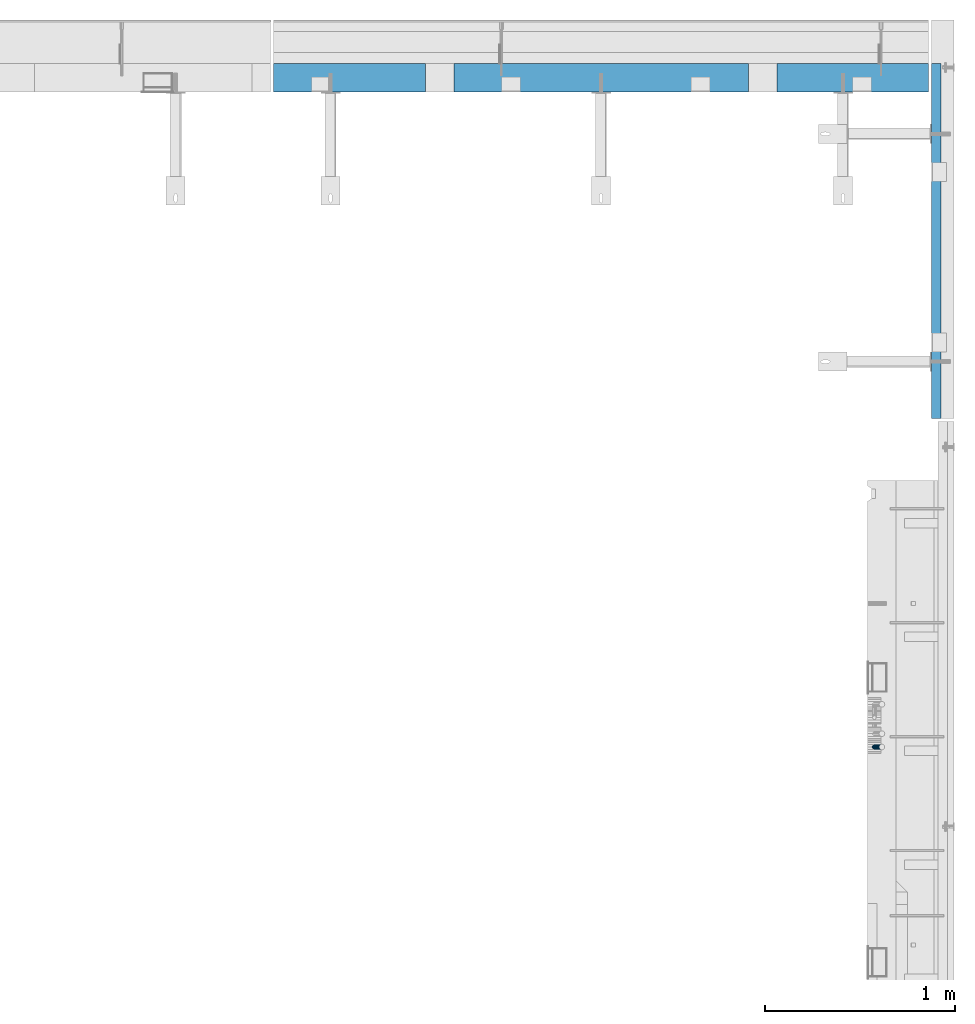
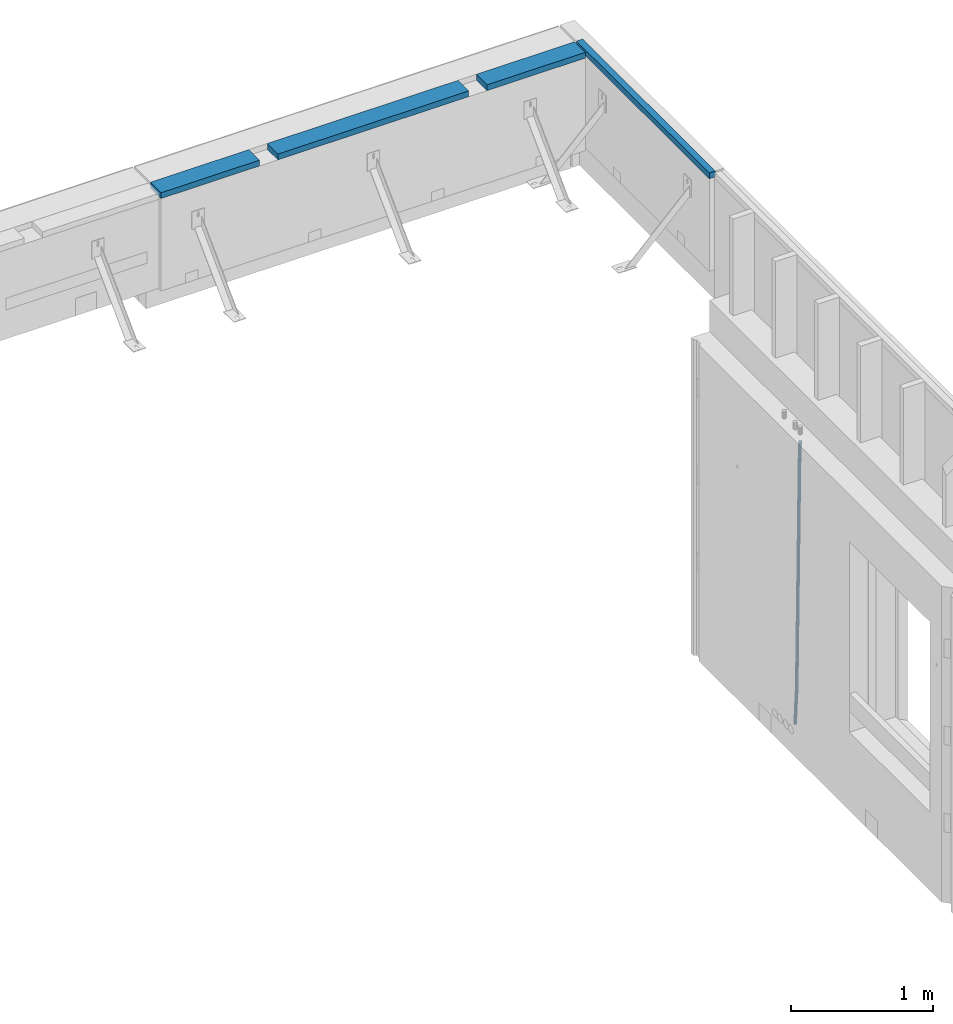
# One storey, part 45 of 153: 3 beams, 3 elements without a shape of their own.
"""IFC2X3 building model written with IfcOpenShell, lengths in millimetres."""

from ifc_helpers import new_model, si_unit, frame, origin_with_axes, place, context, subcontext, project, spatial, faceted_brep, material, type_object, element, aggregate, save


model = new_model("IFC2X3")

# Units and contexts
model_context = context("Model", 3, precision=1e-05, world=origin_with_axes())
body_context = subcontext(model_context, "Body", "Model", "MODEL_VIEW")
ifc_project = project(units=[si_unit("LENGTHUNIT", "METRE", prefix="MILLI"), si_unit("AREAUNIT", "SQUARE_METRE"), si_unit("VOLUMEUNIT", "CUBIC_METRE"), si_unit("MASSUNIT", "GRAM", prefix="KILO"), si_unit("TIMEUNIT", "SECOND"), si_unit("PLANEANGLEUNIT", "RADIAN"), si_unit("SOLIDANGLEUNIT", "STERADIAN"), si_unit("THERMODYNAMICTEMPERATUREUNIT", "DEGREE_CELSIUS"), si_unit("LUMINOUSINTENSITYUNIT", "LUMEN")], contexts=[model_context])

# Site, building, storey
site_placement = place(None, origin_with_axes())
site = spatial("IfcSite", under=ifc_project, at=site_placement, CompositionType="ELEMENT")
building_placement = place(site_placement, origin_with_axes())
building = spatial("IfcBuilding", under=site, at=building_placement, CompositionType="ELEMENT")
storey_placement = place(building_placement, origin_with_axes())
storey = spatial("IfcBuildingStorey", under=building, at=storey_placement, Name="8", CompositionType="ELEMENT", Elevation=0.0)

# Assembly, beam
assembly_1_placement = place(storey_placement, origin_with_axes())
assembly_1 = element("IfcElementAssembly", 1, at=assembly_1_placement, inside=storey, AssemblyPlace="NOTDEFINED", PredefinedType="REINFORCEMENT_UNIT")
ifc_material_1 = material(Name="TIMBER")
beam_type_1 = type_object("IfcBeamType", PredefinedType="NOTDEFINED")
beam_1_placement = place(assembly_1_placement, frame((31779.9999728033, 22695.0, 103545.0), z_axis=(0.0, 0.0, 1.0), x_axis=(1.0, 0.0, 0.0)))
beam_1 = element("IfcBeam", 2, at=beam_1_placement, type_object=beam_type_1, material=ifc_material_1, context=body_context, shape_type="Brep", body=[
    faceted_brep([(0.0, -75.0, -25.0), (1.81898940354586e-12, -75.0000000000009, 25.0), (1.81898940354586e-12, 75.0, 25.0), (0.0, 75.0, -25.0), (800.999675264662, -75.0, -25.0), (800.999675264662, -75.0, 25.0), (800.999696264662, 74.9995409673429, 25.0), (800.999696264662, 75.0, -25.0), (2650.99969626429, 74.9988790673451, 25.0), (2650.99969626429, 75.0000000000036, -25.0), (2650.99967526454, -75.0, -25.0), (2650.99967526454, -75.0, 25.0), (3449.9963989386, -75.0, 25.0), (3449.9963989386, -75.0, -25.0), (3449.99639893861, 75.0000000000036, -25.0), (3449.99639893861, 75.0000000000036, 25.0), (2500.99969626454, 74.9989000673449, 25.0), (2500.99967526454, -75.0000000000036, 25.0), (2500.99967526454, -75.0000000000036, -25.0), (2500.99969626454, 75.0000000000036, -25.0), (950.999696264415, 74.9995199673467, 25.0), (950.999696264415, 75.0000000000036, -25.0), (950.999675264662, -75.0, -25.0), (950.999675264662, -75.0, 25.0)], [[[0, 1, 2, 3]], [[1, 0, 4, 5]], [[2, 1, 5, 6]], [[3, 2, 6, 7]], [[0, 3, 7, 4]], [[6, 5, 4, 7]], [[8, 9, 10, 11]], [[12, 13, 14, 15]], [[12, 15, 8, 11]], [[13, 12, 11, 10]], [[14, 13, 10, 9]], [[15, 14, 9, 8]], [[16, 17, 18, 19]], [[20, 21, 22, 23]], [[21, 20, 16, 19]], [[22, 21, 19, 18]], [[23, 22, 18, 17]], [[20, 23, 17, 16]]]),
])
aggregate(assembly_1, [beam_1])

assembly_2_placement = place(storey_placement, origin_with_axes())
assembly_2 = element("IfcElementAssembly", 3, at=assembly_2_placement, inside=storey, AssemblyPlace="NOTDEFINED", PredefinedType="REINFORCEMENT_UNIT")
ifc_material_2 = material()
beam_type_2 = type_object("IfcBeamType", Name="D25", PredefinedType="NOTDEFINED")
beam_2_placement = place(assembly_2_placement, frame((34944.9999977209, 19170.0002441367, 99990.0), z_axis=(0.999642804629538, 0.000205762999925497, -0.0267249099901003), x_axis=(0.0267249109941254, -4.30000210532798e-08, 0.999642825779465)))
beam_2 = element("IfcBeam", 4, at=beam_2_placement, type_object=beam_type_2, material=ifc_material_2, Name="JM25", ObjectType="D25", context=body_context, shape_type="Brep", body=[
    faceted_brep([(-7.41420080885291e-08, -12.5, -3.63797880709171e-12), (-6.42030499875546e-08, -10.8253175473074, -6.25000000000364), (60.4103898235917, -10.8253175318459, -6.2499999938409), (60.4103898269532, -12.4999999845422, 6.16273609921336e-09), (-3.70782800018787e-08, -6.25000000000364, -10.8253175473074), (60.4103898202884, -6.24999998454587, -10.8253175411446), (-1.45519152283669e-11, -3.63797880709171e-12, -12.5), (60.4103898179019, 1.54577719513327e-08, -12.4999999938373), (3.70637280866504e-08, 6.25, -10.8253175473074), (60.410389817087, 6.25000001545777, -10.825317541141), (6.42030499875546e-08, 10.8253175473001, -6.25000000000364), (60.410389818062, 10.8253175627578, -6.24999999383726), (7.41420080885291e-08, 12.4999999999927, 0.0), (60.4103898205503, 12.5000000154541, 6.16273609921336e-09), (6.42176019027829e-08, 10.8253175473001, 6.24999999999636), (60.4103898238973, 10.8253175627651, 6.2500000061591), (3.70928319171071e-08, 6.24999999999636, 10.8253175473037), (60.4103898272151, 6.25000001546141, 10.8253175534664), (1.45519152283669e-11, -3.63797880709171e-12, 12.4999999999964), (60.4103898296162, 1.54541339725256e-08, 12.5000000061591), (-3.7049176171422e-08, -6.25000000000364, 10.8253175473001), (60.4103898304165, -6.24999998454587, 10.8253175534701), (-6.41884980723262e-08, -10.8253175473074, 6.25), (60.4103898294561, -10.8253175318459, 6.25000000616637), (61.0324985728803, -10.8253175316895, -6.24999999377542), (60.991802792938, -12.4999999843931, 6.22458173893392e-09), (61.0622854283865, -6.24999998437852, -10.8253175410755), (61.0731819955545, 1.5628756955266e-08, -12.4999999937718), (61.0622685480339, 6.25000001562512, -10.8253175410791), (61.032469335245, 10.8253175629216, -6.24999999377178), (60.9917690322181, 12.5000000156033, 6.22458173893392e-09), (60.9510732522613, 10.8253175629034, 6.25000000621731), (60.9212863967696, 6.25000001558874, 10.8253175535247), (60.9103898296162, 1.55814632307738e-08, 12.5000000062137), (60.9213032771368, -6.24999998441126, 10.8253175535174), (60.9511024898966, -10.8253175317113, 6.25000000621731), (61.6545545670233, -10.8253158516927, -6.24189838219536), (61.573166454793, -12.499998414296, 0.00757164385504439), (61.7141257553885, -6.24999822394238, -10.8168280205282), (61.7359179680789, 1.80548886419274e-06, -12.491368569139), (61.7140919992817, 6.25000177601396, -10.8168282403167), (61.6544960997562, 10.8253192428383, -6.2418987628771), (61.5730989426083, 12.5000015856094, 0.0075712042817031), (61.4917108303925, 10.8253190230062, 6.25704123032847), (61.4321396420273, 6.25000139525582, 10.8319708686649), (61.4103474293224, 1.36582457344048e-06, 12.5065114172721), (61.4321733981196, -6.24999860470052, 10.8319710884571), (61.4917692976451, -10.8253160715249, 6.25704161101385), (176.524302641745, -10.8250056210964, -4.74584321979273), (176.442914529529, -12.4996881836996, 1.50362680625403), (176.583873830095, -6.24968799334965, -9.3207728581292), (176.605666042786, 0.000312036081595579, -10.9953134067364), (176.583840074018, 6.25031200660669, -9.32077307791769), (176.524244174492, 10.8256294734347, -4.74584360047811), (176.44284701733, 12.5003118162058, 1.50362636668069), (176.361458905099, 10.8256292535989, 7.75309639272746), (176.301887716749, 6.25031162585219, 12.3280260310676), (176.280095504058, 0.000311596420942806, 14.0025665796711), (176.301921472827, -6.24968837410415, 12.3280262508561), (176.361517372367, -10.8250058409321, 7.75309677341284), (177.085397012124, -10.8250041057399, -4.73853556792164), (176.983633547483, -12.4996867233749, 1.51066909103247), (177.159881729676, -6.24968643771717, -9.31327097355097), (177.187129580227, 0.000313606451527448, -10.987740468332), (177.159839524218, 6.25031356221734, -9.31327130338468), (177.085323910098, 10.8256309887511, -4.73853613920801), (176.983549136537, 12.5003132764905, 1.51066843136869), (176.881785671867, 10.8256306588555, 7.7598730903228), (176.80730095433, 6.25031299082912, 12.3346084959521), (176.780053103794, 0.000312946667690994, 14.0090779907332), (176.807343159802, -6.2496870091054, 12.3346088257895), (176.881858773908, -10.8250044356355, 7.7598736616128), (177.646431799818, -10.8250018318176, -4.72756919822132), (177.524295146417, -12.4996845320202, 1.52123723245313), (177.735828462886, -6.24968410334986, -9.30201312475765), (177.768531371941, 0.00031596292683389, -10.9763759912421), (177.735777808921, 6.25031589654827, -9.30201361973741), (177.646344064575, 10.8256332626152, -4.72757005553649), (177.524193838486, 12.5003154677688, 1.52123624250817), (177.402057185071, 10.8256327675663, 7.77004267317898), (177.312660521988, 6.2503150390985, 12.3444865997226), (177.279957612933, 0.00031497282179771, 14.0188494661961), (177.312711175953, -6.24968496079964, 12.3444870946951), (177.402144920314, -10.8250023268702, 7.77004353049415), (299.377443161706, -10.8245084454466, -2.34813158632096), (299.255306508276, -12.4991911456491, 3.90067484435349), (299.466839824803, -6.24919071697514, -6.92257551286093), (299.499542733873, 0.0008093492979242, -8.59693837933446), (299.466789170867, 6.250809282923, -6.92257600783341), (299.377355426492, 10.8261266489935, -2.34813244364341), (299.255205200388, 12.5008088541435, 3.90067385440125), (299.133068546944, 10.826126153941, 10.1494802850757), (299.043671883861, 6.25080842546959, 14.7239242116229), (299.010968974762, 0.000808359200163977, 16.3982870780892), (299.043722537797, -6.24919157442127, 14.7239247065918), (299.133156282158, -10.8245089404954, 10.1494811423981), (299.98561436501, -10.8245059804758, -2.33624385599614), (299.97179243555, -12.4991882411778, 3.91467976726199), (299.995742293278, -6.24918857328521, -6.91223722345239), (299.999447243041, 0.000811375455668895, -8.58716690387519), (299.995736475976, 6.25081142679483, -6.91223684201032), (299.985604289133, 10.8261291142808, -2.33624319533556), (299.971750386685, 12.5008117588586, 3.91467993563856), (299.957928457196, 10.8261294971744, 10.1656035610831), (299.947800528913, 6.25081208998381, 14.7415969285394), (299.944095579151, 0.00081214124293183, 16.4165266089549), (299.947806346216, -6.24918791008895, 14.7415965471009), (299.957938533058, -10.8245055975785, 10.1656029004225), (300.593832239858, -10.8245078794353, -2.34543881707941), (300.688302931099, -12.4991904788549, 3.90384712594823), (300.524685350189, -6.24919022474205, -6.92023371784308), (300.499390115292, 0.000809814544481924, -8.59472497713432), (300.524724372954, 6.25080977519247, -6.92023401429469), (300.593899829313, 10.8261272150703, -2.34543933054374), (300.688380976673, 12.5008095210287, 3.90384653304136), (300.782851667915, 10.8261269216127, 10.1531324760799), (300.851998557599, 6.25080926691589, 14.7279273768363), (300.877293792495, 0.000809227632998955, 16.4024186361276), (300.851959534804, -6.24919073302226, 14.7279276732806), (300.782784078474, -10.8245081728965, 10.153132989537), (2293.32930409742, -10.8307295605009, -32.4713622331001), (2293.42377478865, -12.5054121599169, -26.2220762900724), (2293.26015720774, -6.2554119058077, -37.0461571338565), (2293.23486197284, -0.00541186651753378, -38.7206483931477), (2293.26019623051, 6.24458809413409, -37.0461574303008), (2293.32937168686, 10.8199055340046, -32.4713627465644), (2293.42385283421, 12.4945878399631, -26.2220768829684), (2293.51832352545, 10.8199052405434, -19.972790939948), (2293.58747041514, 6.24458758585388, -15.3979960391844), (2293.61276565003, -0.00541245343265473, -13.7235047798931), (2293.58743139236, -6.25541241408428, -15.3979957427327), (2293.51825593603, -10.8307298539585, -19.9727904264691), (2294.0420846676, -10.8307317859326, -32.4821379598216), (2294.03681932652, -12.5054140739521, -26.2313442200393), (2294.06778164886, -6.2554144273563, -37.0583666982457), (2294.10702478497, -0.00541458957013674, -38.7338336404937), (2294.14929890928, 6.24458531819619, -37.0595987724118), (2294.18327670435, 10.8199028679592, -32.4842719748667), (2294.1998538474, 12.4945854171456, -26.2338083683717), (2294.19458850632, 10.819903129126, -19.9830146285858), (2294.16889152506, 6.24458577054975, -15.4067858901581), (2294.12964838895, -0.0054140672327776, -13.7313189479173), (2294.08737426462, -6.2554139749991, -15.4055538159919), (2294.05339646956, -10.8307315247621, -19.9808806135297), (2294.75482297382, -10.84002603931, -32.4726521173216), (2294.64982751427, -12.513407826169, -26.2231856868602), (2294.87535820232, -6.26594539088183, -37.0476186524102), (2294.97913588268, -0.0167870967634371, -38.7222267036377), (2295.0383488692, 6.23299192477134, -37.0477663960555), (2295.03713108998, 10.8087684320271, -32.4729080168181), (2294.97580884799, 12.4844668051373, -26.2234811741473), (2294.87081338844, 10.8110850182784, -19.9740147436787), (2294.7502781599, 6.23700436985018, -15.3990482086047), (2294.64650047956, -0.0121539242718427, -13.7244401573698), (2294.58728749304, -6.26193294580662, -15.3989004649666), (2294.58850527227, -10.8377094530588, -19.9737588441894), (2316.44667268227, -11.1228921988077, -32.1839550346631), (2316.34167722271, -12.7962739856739, -25.9344886042054), (2316.56720791078, -6.54881155039038, -36.7589215697517), (2316.67098559113, -0.299653256264719, -38.4335296209792), (2316.73019857766, 5.95012576527006, -36.759069313397), (2316.72898079845, 10.5259022725259, -32.1842109341669), (2316.66765855643, 12.2016006456361, -25.9347840914961), (2316.56266309689, 10.5282188587698, -19.6853176610275), (2316.44212786836, 5.95413821035254, -15.1103511259389), (2316.33835018802, -0.295020083769487, -13.4357430747186), (2316.27913720149, -6.54479910530426, -15.1102033823008), (2316.28035498071, -11.1205756125637, -19.685061761531), (2317.13234804722, -11.1318335458927, -32.1748293731798), (2317.04181141085, -12.8054038787741, -25.9251705100723), (2317.2154741603, -6.5572650749491, -36.7502937866229), (2317.26891617525, -0.307450393454928, -38.4255717558117), (2317.27835434731, 5.94297770185585, -36.7517739018112), (2317.24125972588, 10.5192220504723, -32.1773930078925), (2317.16757178486, 12.1950816748285, -25.9281307404563), (2317.0770351485, 10.5215113419545, -19.6784718773561), (2316.99390903539, 5.94694287101083, -15.1030074639057), (2316.94046702047, -0.302871810494253, -13.4277294947169), (2316.9310288484, -6.55329990579412, -15.1015273487101), (2316.96812346982, -11.1295442544142, -19.6759082426288), (2317.81808136747, -11.1298054502913, -32.1659056455355), (2317.74200467508, -12.803315894289, -25.9160547315114), (2317.86379538118, -6.55536082026447, -36.7418676070083), (2317.8668976831, -0.305700748642266, -38.417815303761), (2317.82655701396, 5.94458339541234, -36.7446799039099), (2317.75358262347, 10.5207330230332, -32.1707766866384), (2317.66752794063, 12.1965725370646, -25.9216793252963), (2317.59145124823, 10.5230620930706, -19.6718284112721), (2317.54573723453, 5.94861746304377, -15.0958664497994), (2317.54263493262, -0.301042608574789, -13.4199187530394), (2317.58297560175, -6.55132675263303, -15.0930541529051), (2317.65594999224, -11.1274763802539, -19.6669573701693), (2417.81884292323, -10.831603083323, -30.8687911350135), (2417.74276623082, -12.505113527317, -24.618940220982), (2417.86455693691, -6.25715845329614, -35.4447530964935), (2417.86765923884, -0.00749838167394046, -37.1207007932499), (2417.82731856969, 6.24278576237703, -35.4475653933878), (2417.75434417921, 10.8189353900088, -30.8736621761236), (2417.66828949639, 12.494774904033, -24.6245648147851), (2417.59221280397, 10.8212644600353, -18.3747139007501), (2417.54649879028, 6.2468198300121, -13.79875193927), (2417.54339648837, -0.00284024161010166, -12.1228042425173), (2417.5837371575, -6.25312438566107, -13.795939642383), (2417.65671154798, -10.8292740132893, -18.3698428596399)], [[[0, 1, 2, 3]], [[1, 4, 5, 2]], [[4, 6, 7, 5]], [[6, 8, 9, 7]], [[8, 10, 11, 9]], [[10, 12, 13, 11]], [[12, 14, 15, 13]], [[14, 16, 17, 15]], [[16, 18, 19, 17]], [[18, 20, 21, 19]], [[20, 22, 23, 21]], [[22, 0, 3, 23]], [[22, 20, 18, 16, 14, 12, 10, 8, 6, 4, 1, 0]], [[3, 2, 24, 25]], [[2, 5, 26, 24]], [[5, 7, 27, 26]], [[7, 9, 28, 27]], [[9, 11, 29, 28]], [[11, 13, 30, 29]], [[13, 15, 31, 30]], [[15, 17, 32, 31]], [[17, 19, 33, 32]], [[19, 21, 34, 33]], [[21, 23, 35, 34]], [[23, 3, 25, 35]], [[25, 24, 36, 37]], [[24, 26, 38, 36]], [[26, 27, 39, 38]], [[27, 28, 40, 39]], [[28, 29, 41, 40]], [[29, 30, 42, 41]], [[30, 31, 43, 42]], [[31, 32, 44, 43]], [[32, 33, 45, 44]], [[33, 34, 46, 45]], [[34, 35, 47, 46]], [[35, 25, 37, 47]], [[37, 36, 48, 49]], [[36, 38, 50, 48]], [[38, 39, 51, 50]], [[39, 40, 52, 51]], [[40, 41, 53, 52]], [[41, 42, 54, 53]], [[42, 43, 55, 54]], [[43, 44, 56, 55]], [[44, 45, 57, 56]], [[45, 46, 58, 57]], [[46, 47, 59, 58]], [[47, 37, 49, 59]], [[49, 48, 60, 61]], [[48, 50, 62, 60]], [[50, 51, 63, 62]], [[51, 52, 64, 63]], [[52, 53, 65, 64]], [[53, 54, 66, 65]], [[54, 55, 67, 66]], [[55, 56, 68, 67]], [[56, 57, 69, 68]], [[57, 58, 70, 69]], [[58, 59, 71, 70]], [[59, 49, 61, 71]], [[61, 60, 72, 73]], [[60, 62, 74, 72]], [[62, 63, 75, 74]], [[63, 64, 76, 75]], [[64, 65, 77, 76]], [[65, 66, 78, 77]], [[66, 67, 79, 78]], [[67, 68, 80, 79]], [[68, 69, 81, 80]], [[69, 70, 82, 81]], [[70, 71, 83, 82]], [[71, 61, 73, 83]], [[73, 72, 84, 85]], [[72, 74, 86, 84]], [[74, 75, 87, 86]], [[75, 76, 88, 87]], [[76, 77, 89, 88]], [[77, 78, 90, 89]], [[78, 79, 91, 90]], [[79, 80, 92, 91]], [[80, 81, 93, 92]], [[81, 82, 94, 93]], [[82, 83, 95, 94]], [[83, 73, 85, 95]], [[85, 84, 96, 97]], [[84, 86, 98, 96]], [[86, 87, 99, 98]], [[87, 88, 100, 99]], [[88, 89, 101, 100]], [[89, 90, 102, 101]], [[90, 91, 103, 102]], [[91, 92, 104, 103]], [[92, 93, 105, 104]], [[93, 94, 106, 105]], [[94, 95, 107, 106]], [[95, 85, 97, 107]], [[97, 96, 108, 109]], [[96, 98, 110, 108]], [[98, 99, 111, 110]], [[99, 100, 112, 111]], [[100, 101, 113, 112]], [[101, 102, 114, 113]], [[102, 103, 115, 114]], [[103, 104, 116, 115]], [[104, 105, 117, 116]], [[105, 106, 118, 117]], [[106, 107, 119, 118]], [[107, 97, 109, 119]], [[109, 108, 120, 121]], [[108, 110, 122, 120]], [[110, 111, 123, 122]], [[111, 112, 124, 123]], [[112, 113, 125, 124]], [[113, 114, 126, 125]], [[114, 115, 127, 126]], [[115, 116, 128, 127]], [[116, 117, 129, 128]], [[117, 118, 130, 129]], [[118, 119, 131, 130]], [[119, 109, 121, 131]], [[121, 120, 132, 133]], [[120, 122, 134, 132]], [[122, 123, 135, 134]], [[123, 124, 136, 135]], [[124, 125, 137, 136]], [[125, 126, 138, 137]], [[126, 127, 139, 138]], [[127, 128, 140, 139]], [[128, 129, 141, 140]], [[129, 130, 142, 141]], [[130, 131, 143, 142]], [[131, 121, 133, 143]], [[133, 132, 144, 145]], [[132, 134, 146, 144]], [[134, 135, 147, 146]], [[135, 136, 148, 147]], [[136, 137, 149, 148]], [[137, 138, 150, 149]], [[138, 139, 151, 150]], [[139, 140, 152, 151]], [[140, 141, 153, 152]], [[141, 142, 154, 153]], [[142, 143, 155, 154]], [[143, 133, 145, 155]], [[145, 144, 156, 157]], [[144, 146, 158, 156]], [[146, 147, 159, 158]], [[147, 148, 160, 159]], [[148, 149, 161, 160]], [[149, 150, 162, 161]], [[150, 151, 163, 162]], [[151, 152, 164, 163]], [[152, 153, 165, 164]], [[153, 154, 166, 165]], [[154, 155, 167, 166]], [[155, 145, 157, 167]], [[157, 156, 168, 169]], [[156, 158, 170, 168]], [[158, 159, 171, 170]], [[159, 160, 172, 171]], [[160, 161, 173, 172]], [[161, 162, 174, 173]], [[162, 163, 175, 174]], [[163, 164, 176, 175]], [[164, 165, 177, 176]], [[165, 166, 178, 177]], [[166, 167, 179, 178]], [[167, 157, 169, 179]], [[169, 168, 180, 181]], [[168, 170, 182, 180]], [[170, 171, 183, 182]], [[171, 172, 184, 183]], [[172, 173, 185, 184]], [[173, 174, 186, 185]], [[174, 175, 187, 186]], [[175, 176, 188, 187]], [[176, 177, 189, 188]], [[177, 178, 190, 189]], [[178, 179, 191, 190]], [[179, 169, 181, 191]], [[181, 180, 192, 193]], [[180, 182, 194, 192]], [[182, 183, 195, 194]], [[183, 184, 196, 195]], [[184, 185, 197, 196]], [[185, 186, 198, 197]], [[186, 187, 199, 198]], [[187, 188, 200, 199]], [[188, 189, 201, 200]], [[189, 190, 202, 201]], [[190, 191, 203, 202]], [[191, 181, 193, 203]], [[194, 195, 196, 197, 198, 199, 200, 201, 202, 203, 193, 192]]]),
])
aggregate(assembly_2, [beam_2])

assembly_3_placement = place(storey_placement, origin_with_axes())
assembly_3 = element("IfcElementAssembly", 5, at=assembly_3_placement, inside=storey, AssemblyPlace="NOTDEFINED", PredefinedType="REINFORCEMENT_UNIT")
ifc_material_3 = material(Name="TIMBER/T24")
beam_type_3 = type_object("IfcBeamType", Name="PK50X50", PredefinedType="NOTDEFINED")
beam_3_placement = place(assembly_3_placement, frame((35269.9998565249, 20900.0033135106, 103545.0), z_axis=(0.0, 0.0, 1.0), x_axis=(-1.19799915409591e-06, 0.999999999999282, 0.0)))
beam_3 = element("IfcBeam", 6, at=beam_3_placement, type_object=beam_type_3, material=ifc_material_3, ObjectType="PK50X50", context=body_context, shape_type="Brep", body=[
    faceted_brep([(0.0, 25.0, 25.0), (0.0, -25.0, 25.0), (1870.00655944758, -25.0000000000073, 25.0), (1870.00655944757, 25.0, 25.0), (0.0, -25.0, -25.0), (1870.00655944758, -25.0000000000073, -25.0), (0.0, 25.0, -25.0), (1870.00655944757, 25.0, -25.0)], [[[0, 1, 2, 3]], [[1, 4, 5, 2]], [[4, 6, 7, 5]], [[6, 0, 3, 7]], [[5, 7, 3, 2]], [[4, 1, 0, 6]]]),
])
aggregate(assembly_3, [beam_3])

save(model, "model.ifc")
